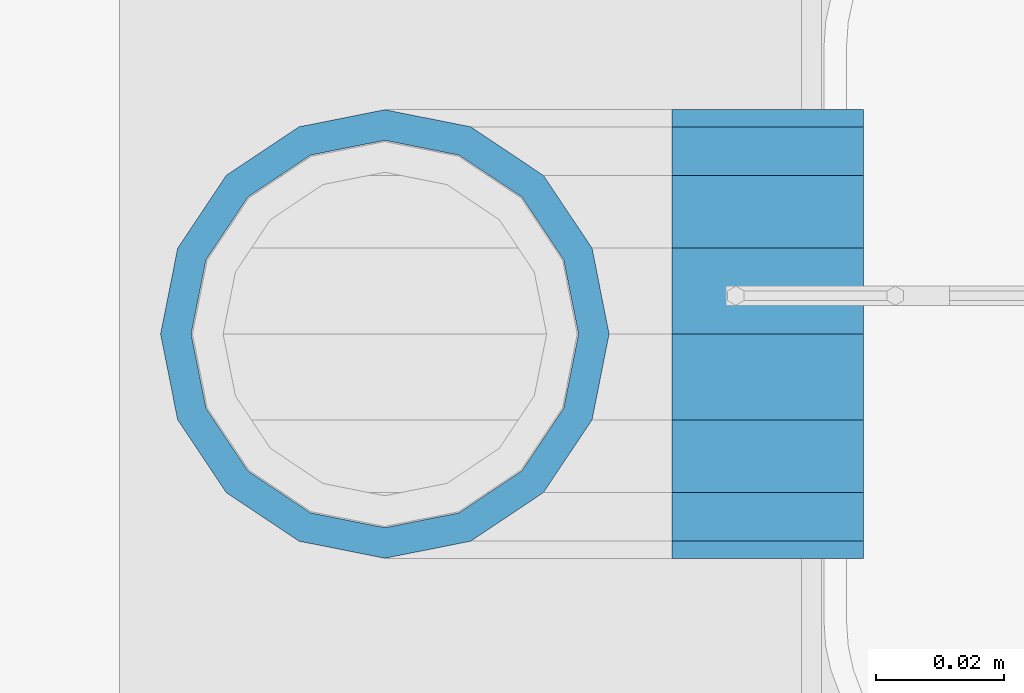
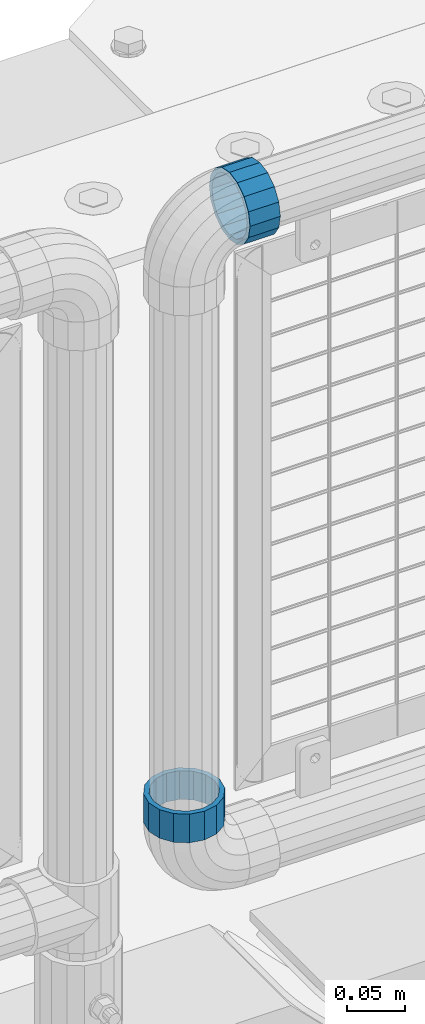
# One storey, part 125 of 193: 2 beams.
"""IFC2X3 building model written with IfcOpenShell, lengths in millimetres."""

from ifc_helpers import new_model, si_unit, frame, origin_with_axes, place, context, subcontext, project, spatial, faceted_brep, material, type_object, element, save


model = new_model("IFC2X3")

# Units and contexts
model_context = context("Model", 3, precision=1e-05, world=origin_with_axes())
body_context = subcontext(model_context, "Body", "Model", "MODEL_VIEW")
ifc_project = project(units=[si_unit("LENGTHUNIT", "METRE", prefix="MILLI"), si_unit("AREAUNIT", "SQUARE_METRE"), si_unit("VOLUMEUNIT", "CUBIC_METRE"), si_unit("MASSUNIT", "GRAM", prefix="KILO"), si_unit("TIMEUNIT", "SECOND"), si_unit("PLANEANGLEUNIT", "RADIAN"), si_unit("SOLIDANGLEUNIT", "STERADIAN"), si_unit("THERMODYNAMICTEMPERATUREUNIT", "DEGREE_CELSIUS"), si_unit("LUMINOUSINTENSITYUNIT", "LUMEN")], contexts=[model_context])

# Site, building, storey
site_placement = place(None, origin_with_axes())
site = spatial("IfcSite", under=ifc_project, at=site_placement, CompositionType="ELEMENT")
building_placement = place(site_placement, origin_with_axes())
building = spatial("IfcBuilding", under=site, at=building_placement, Name="Standard", CompositionType="ELEMENT")
storey_placement = place(building_placement, origin_with_axes())
storey = spatial("IfcBuildingStorey", under=building, at=storey_placement, Name="Undefined", CompositionType="ELEMENT", Elevation=0.0)

# Beams
ifc_material = material(Name="Misc_Undefined")
beam_type = type_object("IfcBeamType", PredefinedType="NOTDEFINED")
beam_1_placement = place(storey_placement, frame((-30118.39, 28664.5, 373.170000000002), z_axis=(-1.0, 0.0, 0.0), x_axis=(0.0, 0.0, -1.0)))
element("IfcBeam", 1, at=beam_1_placement, inside=storey, type_object=beam_type, material=ifc_material, context=body_context, shape_type="Brep", body=[
    faceted_brep([(0.0, -30.3499999999985, 0.0), (0.0, -28.0397438117179, 11.614442172282), (30.0, -28.0397438117179, 11.6144421722805), (30.0, -30.3499999999985, 0.0), (0.0, -21.46069080901, 21.46069080901), (30.0, -21.46069080901, 21.4606908090117), (0.0, -11.614442172282, 28.0397438117179), (30.0, -11.614442172282, 28.0397438117176), (0.0, 0.0, 30.3499999999985), (30.0, 0.0, 30.35), (0.0, 11.614442172282, 28.0397438117179), (30.0, 11.614442172282, 28.0397438117176), (0.0, 21.46069080901, 21.46069080901), (30.0, 21.46069080901, 21.4606908090117), (0.0, 28.0397438117179, 11.614442172282), (30.0, 28.0397438117179, 11.6144421722805), (0.0, 30.3499999999985, 0.0), (30.0, 30.3499999999985, 0.0), (0.0, 28.0397438117179, -11.614442172282), (30.0, 28.0397438117179, -11.6144421722805), (0.0, 21.46069080901, -21.46069080901), (30.0, 21.46069080901, -21.4606908090117), (0.0, 11.614442172282, -28.0397438117179), (30.0, 11.614442172282, -28.0397438117176), (0.0, 0.0, -30.3499999999985), (30.0, 0.0, -30.35), (0.0, -11.614442172282, -28.0397438117179), (30.0, -11.614442172282, -28.0397438117176), (0.0, -21.46069080901, -21.46069080901), (30.0, -21.46069080901, -21.4606908090117), (0.0, -28.0397438117179, -11.614442172282), (30.0, -28.0397438117179, -11.6144421722805), (0.0, -35.1500000000015, 0.0), (0.0, -32.4743655677703, -13.4513226476338), (30.0, -32.4743655677703, -13.4513226476329), (30.0, -35.1500000000015, 0.0), (0.0, -24.8548033587067, -24.8548033587067), (30.0, -24.8548033587067, -24.8548033587072), (0.0, -13.4513226476338, -32.4743655677703), (30.0, -13.4513226476338, -32.4743655677718), (0.0, 0.0, -35.1500000000015), (30.0, 0.0, -35.15), (0.0, 13.4513226476338, -32.4743655677703), (30.0, 13.4513226476338, -32.4743655677718), (0.0, 24.8548033587067, -24.8548033587067), (30.0, 24.8548033587067, -24.8548033587072), (0.0, 32.4743655677703, -13.4513226476338), (30.0, 32.4743655677703, -13.4513226476329), (0.0, 35.1500000000015, 0.0), (30.0, 35.1500000000015, 0.0), (0.0, 32.4743655677703, 13.4513226476338), (30.0, 32.4743655677703, 13.4513226476329), (0.0, 24.8548033587067, 24.8548033587067), (30.0, 24.8548033587067, 24.8548033587072), (0.0, 13.4513226476338, 32.4743655677703), (30.0, 13.4513226476338, 32.4743655677718), (0.0, 0.0, 35.1500000000015), (30.0, 0.0, 35.15), (0.0, -13.4513226476338, 32.4743655677703), (30.0, -13.4513226476338, 32.4743655677718), (0.0, -24.8548033587067, 24.8548033587067), (30.0, -24.8548033587067, 24.8548033587072), (0.0, -32.4743655677703, 13.4513226476338), (30.0, -32.4743655677703, 13.4513226476329)], [[[0, 1, 2, 3]], [[1, 4, 5, 2]], [[4, 6, 7, 5]], [[6, 8, 9, 7]], [[8, 10, 11, 9]], [[10, 12, 13, 11]], [[12, 14, 15, 13]], [[14, 16, 17, 15]], [[16, 18, 19, 17]], [[18, 20, 21, 19]], [[20, 22, 23, 21]], [[22, 24, 25, 23]], [[24, 26, 27, 25]], [[26, 28, 29, 27]], [[28, 30, 31, 29]], [[30, 0, 3, 31]], [[32, 33, 34, 35]], [[33, 36, 37, 34]], [[36, 38, 39, 37]], [[38, 40, 41, 39]], [[40, 42, 43, 41]], [[42, 44, 45, 43]], [[44, 46, 47, 45]], [[46, 48, 49, 47]], [[48, 50, 51, 49]], [[50, 52, 53, 51]], [[52, 54, 55, 53]], [[54, 56, 57, 55]], [[56, 58, 59, 57]], [[58, 60, 61, 59]], [[60, 62, 63, 61]], [[62, 32, 35, 63]], [[37, 39, 41, 43, 45, 47, 49, 51, 53, 55, 57, 59, 61, 63, 35, 34], [5, 7, 9, 11, 13, 15, 17, 19, 21, 23, 25, 27, 29, 31, 3, 2]], [[62, 60, 58, 56, 54, 52, 50, 48, 46, 44, 42, 40, 38, 36, 33, 32], [30, 28, 26, 24, 22, 20, 18, 16, 14, 12, 10, 8, 6, 4, 1, 0]]]),
])
beam_2_placement = place(storey_placement, frame((-30073.39, 28664.5, 969.849999999999), z_axis=(0.0, 0.0, 1.0), x_axis=(1.0, 0.0, 0.0)))
element("IfcBeam", 2, at=beam_2_placement, inside=storey, type_object=beam_type, material=ifc_material, context=body_context, shape_type="Brep", body=[
    faceted_brep([(0.0, -30.3499999999985, 0.0), (0.0, -28.0397438117179, 11.614442172282), (30.0, -28.0397438117179, 11.6144421722805), (30.0, -30.3499999999985, 0.0), (0.0, -21.46069080901, 21.46069080901), (30.0, -21.46069080901, 21.4606908090117), (0.0, -11.614442172282, 28.0397438117179), (30.0, -11.614442172282, 28.0397438117176), (0.0, 0.0, 30.3499999999985), (30.0, 0.0, 30.35), (0.0, 11.614442172282, 28.0397438117179), (30.0, 11.614442172282, 28.0397438117176), (0.0, 21.46069080901, 21.46069080901), (30.0, 21.46069080901, 21.4606908090117), (0.0, 28.0397438117179, 11.614442172282), (30.0, 28.0397438117179, 11.6144421722805), (0.0, 30.3499999999985, 0.0), (30.0, 30.3499999999985, 0.0), (0.0, 28.0397438117179, -11.614442172282), (30.0, 28.0397438117179, -11.6144421722805), (0.0, 21.46069080901, -21.46069080901), (30.0, 21.46069080901, -21.4606908090117), (0.0, 11.614442172282, -28.0397438117179), (30.0, 11.614442172282, -28.0397438117176), (0.0, 0.0, -30.3499999999985), (30.0, 0.0, -30.35), (0.0, -11.614442172282, -28.0397438117179), (30.0, -11.614442172282, -28.0397438117176), (0.0, -21.46069080901, -21.46069080901), (30.0, -21.46069080901, -21.4606908090117), (0.0, -28.0397438117179, -11.614442172282), (30.0, -28.0397438117179, -11.6144421722805), (0.0, -35.1500000000015, 0.0), (0.0, -32.4743655677703, -13.4513226476338), (30.0, -32.4743655677703, -13.4513226476329), (30.0, -35.1500000000015, 0.0), (0.0, -24.8548033587067, -24.8548033587067), (30.0, -24.8548033587067, -24.8548033587072), (0.0, -13.4513226476338, -32.4743655677703), (30.0, -13.4513226476338, -32.4743655677718), (0.0, 0.0, -35.1500000000015), (30.0, 0.0, -35.15), (0.0, 13.4513226476338, -32.4743655677703), (30.0, 13.4513226476338, -32.4743655677718), (0.0, 24.8548033587067, -24.8548033587067), (30.0, 24.8548033587067, -24.8548033587072), (0.0, 32.4743655677703, -13.4513226476338), (30.0, 32.4743655677703, -13.4513226476329), (0.0, 35.1500000000015, 0.0), (30.0, 35.1500000000015, 0.0), (0.0, 32.4743655677703, 13.4513226476338), (30.0, 32.4743655677703, 13.4513226476329), (0.0, 24.8548033587067, 24.8548033587067), (30.0, 24.8548033587067, 24.8548033587072), (0.0, 13.4513226476338, 32.4743655677703), (30.0, 13.4513226476338, 32.4743655677718), (0.0, 0.0, 35.1500000000015), (30.0, 0.0, 35.15), (0.0, -13.4513226476338, 32.4743655677703), (30.0, -13.4513226476338, 32.4743655677718), (0.0, -24.8548033587067, 24.8548033587067), (30.0, -24.8548033587067, 24.8548033587072), (0.0, -32.4743655677703, 13.4513226476338), (30.0, -32.4743655677703, 13.4513226476329)], [[[0, 1, 2, 3]], [[1, 4, 5, 2]], [[4, 6, 7, 5]], [[6, 8, 9, 7]], [[8, 10, 11, 9]], [[10, 12, 13, 11]], [[12, 14, 15, 13]], [[14, 16, 17, 15]], [[16, 18, 19, 17]], [[18, 20, 21, 19]], [[20, 22, 23, 21]], [[22, 24, 25, 23]], [[24, 26, 27, 25]], [[26, 28, 29, 27]], [[28, 30, 31, 29]], [[30, 0, 3, 31]], [[32, 33, 34, 35]], [[33, 36, 37, 34]], [[36, 38, 39, 37]], [[38, 40, 41, 39]], [[40, 42, 43, 41]], [[42, 44, 45, 43]], [[44, 46, 47, 45]], [[46, 48, 49, 47]], [[48, 50, 51, 49]], [[50, 52, 53, 51]], [[52, 54, 55, 53]], [[54, 56, 57, 55]], [[56, 58, 59, 57]], [[58, 60, 61, 59]], [[60, 62, 63, 61]], [[62, 32, 35, 63]], [[37, 39, 41, 43, 45, 47, 49, 51, 53, 55, 57, 59, 61, 63, 35, 34], [5, 7, 9, 11, 13, 15, 17, 19, 21, 23, 25, 27, 29, 31, 3, 2]], [[62, 60, 58, 56, 54, 52, 50, 48, 46, 44, 42, 40, 38, 36, 33, 32], [30, 28, 26, 24, 22, 20, 18, 16, 14, 12, 10, 8, 6, 4, 1, 0]]]),
])

save(model, "model.ifc")
